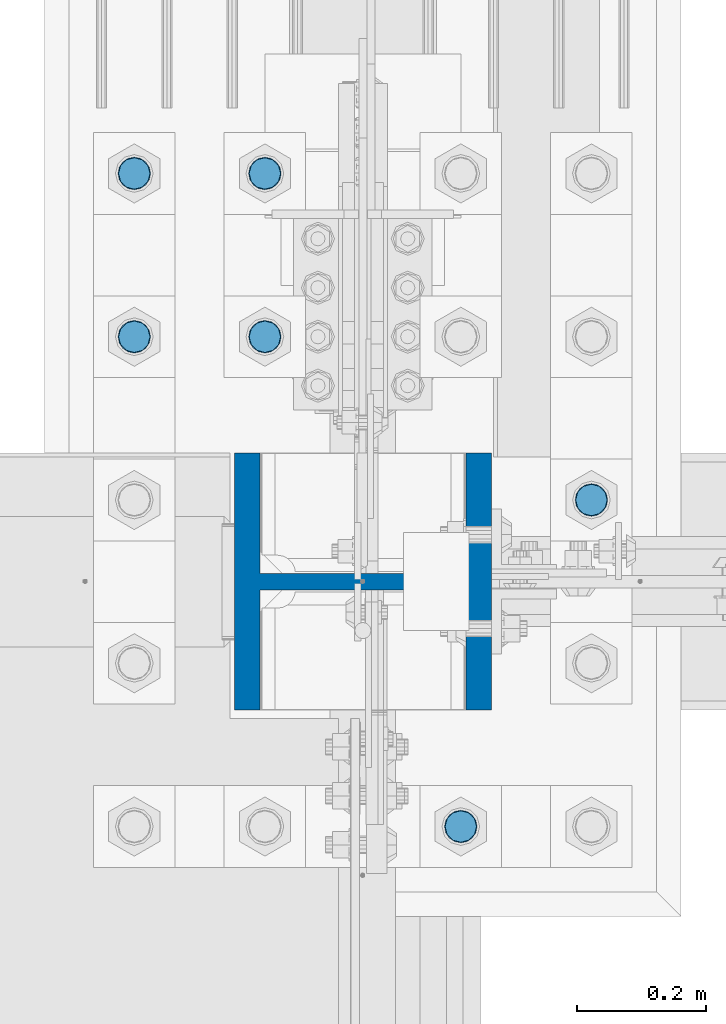
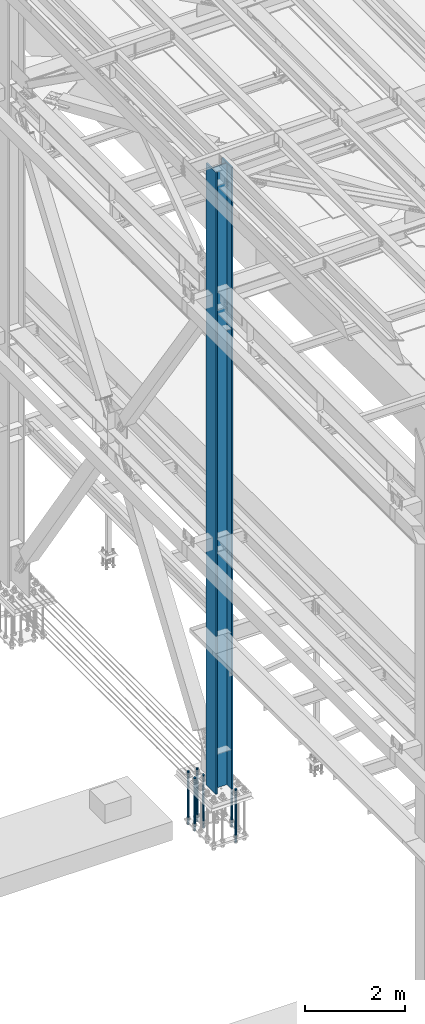
# One storey, part 1327 of 3843: 7 columns, 2 elements without a shape of their own.
"""IFC2X3 building model written with IfcOpenShell, lengths in millimetres."""

from ifc_helpers import new_model, si_unit, frame, origin_with_axes, place, context, subcontext, project, spatial, faceted_brep, material, type_object, element, aggregate, save


model = new_model("IFC2X3")

# Units and contexts
model_context = context("Model", 3, precision=1e-05, world=origin_with_axes())
body_context = subcontext(model_context, "Body", "Model", "MODEL_VIEW")
ifc_project = project(units=[si_unit("LENGTHUNIT", "METRE", prefix="MILLI"), si_unit("AREAUNIT", "SQUARE_METRE"), si_unit("VOLUMEUNIT", "CUBIC_METRE"), si_unit("MASSUNIT", "GRAM", prefix="KILO"), si_unit("TIMEUNIT", "SECOND"), si_unit("PLANEANGLEUNIT", "RADIAN"), si_unit("SOLIDANGLEUNIT", "STERADIAN"), si_unit("THERMODYNAMICTEMPERATUREUNIT", "DEGREE_CELSIUS"), si_unit("LUMINOUSINTENSITYUNIT", "LUMEN")], contexts=[model_context])

# Site, building, storey
site_placement = place(None, origin_with_axes())
site = spatial("IfcSite", under=ifc_project, at=site_placement, CompositionType="ELEMENT")
building_placement = place(site_placement, origin_with_axes())
building = spatial("IfcBuilding", under=site, at=building_placement, Name="Undefined", CompositionType="ELEMENT")
storey_placement = place(building_placement, origin_with_axes())
storey = spatial("IfcBuildingStorey", under=building, at=storey_placement, Name="Undefined", CompositionType="ELEMENT", Elevation=0.0)

# Assembly, columns
assembly_1_placement = place(storey_placement, origin_with_axes())
assembly_1 = element("IfcElementAssembly", 1, at=assembly_1_placement, inside=storey, Name="TEMPLATE", AssemblyPlace="NOTDEFINED", PredefinedType="RIGID_FRAME")
ifc_material_1 = material(Name="Undefined/F1554-GR.55")
column_type_1 = type_object("IfcColumnType", PredefinedType="NOTDEFINED")
column_1_placement = place(assembly_1_placement, frame((36931.6, 50685.7, 30022.8), z_axis=(1.0, 0.0, 0.0), x_axis=(0.0, 0.0, -1.0)))
column_1 = element("IfcColumn", 2, at=column_1_placement, type_object=column_type_1, material=ifc_material_1, Name="ANCHOR_ROD", context=body_context, shape_type="Brep", body=[
    faceted_brep([(-266.700000000001, -21.2176223927236, 12.25), (-266.700000000001, -12.25, 21.2176223927163), (-266.700000000001, 0.0, 24.5), (-266.700000000001, 12.25, 21.2176223927163), (-266.700000000001, 21.2176223927236, 12.25), (-266.700000000001, 24.5, 0.0), (-266.700000000001, 21.2176223927236, -12.25), (-266.700000000001, 12.25, -21.2176223927163), (-266.700000000001, 0.0, -24.5), (-266.700000000001, -12.25, -21.2176223927163), (-266.700000000001, -21.2176223927236, -12.25), (-266.700000000001, -24.5, 0.0), (0.0, 24.5000000000146, 0.0), (0.0, 21.2176223927381, -12.25), (0.0, 12.2500000000146, -21.2176223927163), (0.0, 1.45519152283669e-11, -24.5), (0.0, -12.2499999999854, -21.2176223927163), (0.0, -21.217622392709, -12.25), (0.0, -24.4999999999854, 0.0), (0.0, -21.217622392709, 12.25), (0.0, -12.2499999999854, 21.2176223927163), (0.0, 1.45519152283669e-11, 24.5), (0.0, 12.2500000000146, 21.2176223927163), (0.0, 21.2176223927381, 12.25), (0.0, -23.4665401257807, 9.72015918207035), (0.0, -17.9605122421344, 17.9605122421417), (0.0, -9.72015918207762, 23.466540125788), (0.0, 0.0, 25.4000000000015), (0.0, 9.72015918207762, 23.466540125788), (0.0, 17.9605122421344, 17.9605122421417), (0.0, 23.4665401257807, 9.72015918207035), (0.0, 25.3999996185303, 0.0), (0.0, 23.4665401257807, -9.72015918207035), (0.0, 17.9605122421344, -17.9605122421417), (0.0, 9.72015918207762, -23.466540125788), (0.0, 0.0, -25.4000000000015), (0.0, -9.72015918207762, -23.466540125788), (0.0, -17.9605122421344, -17.9605122421417), (0.0, -23.4665401257807, -9.72015918207035), (0.0, -25.3999996185303, 0.0), (812.799999999999, -25.4000000000015, 0.0), (812.799999999999, -23.466540125788, 9.72015918207398), (812.799999999999, -17.9605122421417, 17.9605122421381), (812.799999999999, -9.72015918207035, 23.466540125788), (812.799999999999, 0.0, 25.4000000000015), (812.799999999999, 9.72015918207035, 23.466540125788), (812.799999999999, 17.9605122421417, 17.9605122421381), (812.799999999999, 23.466540125788, 9.72015918207398), (812.799999999999, 25.4000000000015, 0.0), (812.799999999999, 23.466540125788, -9.72015918207398), (812.799999999999, 17.9605122421417, -17.9605122421381), (812.799999999999, 9.72015918207035, -23.466540125788), (812.799999999999, 0.0, -25.4000000000015), (812.799999999999, -9.72015918207035, -23.466540125788), (812.799999999999, -17.9605122421417, -17.9605122421381), (812.799999999999, -23.466540125788, -9.72015918207398), (812.799999999999, -12.25, 21.2176223927199), (812.799999999999, 0.0, 24.5), (812.799999999999, 12.25, 21.2176223927199), (812.799999999999, 21.2176223927163, 12.25), (812.799999999999, 24.5, 0.0), (812.799999999999, 21.2176223927163, -12.25), (812.799999999999, 12.25, -21.2176223927199), (812.799999999999, 0.0, -24.5), (812.799999999999, -12.25, -21.2176223927199), (812.799999999999, -21.2176223927163, -12.25), (812.799999999999, -24.5, 0.0), (812.799999999999, -21.2176223927163, 12.25), (1041.4, -12.25, -21.2176223927199), (1041.4, 0.0, -24.5), (1041.4, 12.25, -21.2176223927199), (1041.4, 21.2176223927163, -12.25), (1041.4, 24.5, 0.0), (1041.4, 21.2176223927163, 12.25), (1041.4, 12.25, 21.2176223927199), (1041.4, 0.0, 24.5), (1041.4, -12.25, 21.2176223927199), (1041.4, -21.2176223927163, 12.25), (1041.4, -24.5, 0.0), (1041.4, -21.2176223927163, -12.25)], [[[0, 1, 2, 3, 4, 5, 6, 7, 8, 9, 10, 11]], [[6, 5, 12, 13]], [[7, 6, 13, 14]], [[8, 7, 14, 15]], [[9, 8, 15, 16]], [[10, 9, 16, 17]], [[11, 10, 17, 18]], [[0, 11, 18, 19]], [[1, 0, 19, 20]], [[2, 1, 20, 21]], [[3, 2, 21, 22]], [[4, 3, 22, 23]], [[5, 4, 23, 12]], [[24, 25, 26, 27, 28, 29, 30, 31, 32, 33, 34, 35, 36, 37, 38, 39], [22, 21, 20, 19, 18, 17, 16, 15, 14, 13, 12, 23]], [[24, 39, 40, 41]], [[25, 24, 41, 42]], [[26, 25, 42, 43]], [[27, 26, 43, 44]], [[28, 27, 44, 45]], [[29, 28, 45, 46]], [[30, 29, 46, 47]], [[31, 30, 47, 48]], [[32, 31, 48, 49]], [[33, 32, 49, 50]], [[34, 33, 50, 51]], [[35, 34, 51, 52]], [[36, 35, 52, 53]], [[37, 36, 53, 54]], [[38, 37, 54, 55]], [[39, 38, 55, 40]], [[54, 53, 52, 51, 50, 49, 48, 47, 46, 45, 44, 43, 42, 41, 40, 55], [56, 57, 58, 59, 60, 61, 62, 63, 64, 65, 66, 67]], [[68, 69, 70, 71, 72, 73, 74, 75, 76, 77, 78, 79]], [[76, 75, 57, 56]], [[77, 76, 56, 67]], [[78, 77, 67, 66]], [[79, 78, 66, 65]], [[68, 79, 65, 64]], [[69, 68, 64, 63]], [[70, 69, 63, 62]], [[71, 70, 62, 61]], [[72, 71, 61, 60]], [[73, 72, 60, 59]], [[74, 73, 59, 58]], [[75, 74, 58, 57]]]),
])
column_2_placement = place(assembly_1_placement, frame((36728.4, 50177.7, 30022.8), z_axis=(1.0, 0.0, 0.0), x_axis=(0.0, 0.0, -1.0)))
column_2 = element("IfcColumn", 3, at=column_2_placement, type_object=column_type_1, material=ifc_material_1, Name="ANCHOR_ROD", context=body_context, shape_type="Brep", body=[
    faceted_brep([(-266.700000000001, -21.2176223927236, 12.25), (-266.700000000001, -12.25, 21.2176223927163), (-266.700000000001, 0.0, 24.5), (-266.700000000001, 12.25, 21.2176223927163), (-266.700000000001, 21.2176223927236, 12.25), (-266.700000000001, 24.5, 0.0), (-266.700000000001, 21.2176223927236, -12.25), (-266.700000000001, 12.25, -21.2176223927163), (-266.700000000001, 0.0, -24.5), (-266.700000000001, -12.25, -21.2176223927163), (-266.700000000001, -21.2176223927236, -12.25), (-266.700000000001, -24.5, 0.0), (0.0, 24.5000000000146, 0.0), (0.0, 21.2176223927381, -12.25), (0.0, 12.2500000000146, -21.2176223927163), (0.0, 1.45519152283669e-11, -24.5), (0.0, -12.2499999999854, -21.2176223927163), (0.0, -21.217622392709, -12.25), (0.0, -24.4999999999854, 0.0), (0.0, -21.217622392709, 12.25), (0.0, -12.2499999999854, 21.2176223927163), (0.0, 1.45519152283669e-11, 24.5), (0.0, 12.2500000000146, 21.2176223927163), (0.0, 21.2176223927381, 12.25), (0.0, -23.4665401257807, 9.72015918207035), (0.0, -17.9605122421344, 17.9605122421417), (0.0, -9.72015918207762, 23.466540125788), (0.0, 0.0, 25.4000000000015), (0.0, 9.72015918207762, 23.466540125788), (0.0, 17.9605122421344, 17.9605122421417), (0.0, 23.4665401257807, 9.72015918207035), (0.0, 25.3999996185303, 0.0), (0.0, 23.4665401257807, -9.72015918207035), (0.0, 17.9605122421344, -17.9605122421417), (0.0, 9.72015918207762, -23.466540125788), (0.0, 0.0, -25.4000000000015), (0.0, -9.72015918207762, -23.466540125788), (0.0, -17.9605122421344, -17.9605122421417), (0.0, -23.4665401257807, -9.72015918207035), (0.0, -25.3999996185303, 0.0), (812.799999999999, -25.4000000000015, 0.0), (812.799999999999, -23.466540125788, 9.72015918207398), (812.799999999999, -17.9605122421417, 17.9605122421381), (812.799999999999, -9.72015918207035, 23.466540125788), (812.799999999999, 0.0, 25.4000000000015), (812.799999999999, 9.72015918207035, 23.466540125788), (812.799999999999, 17.9605122421417, 17.9605122421381), (812.799999999999, 23.466540125788, 9.72015918207398), (812.799999999999, 25.4000000000015, 0.0), (812.799999999999, 23.466540125788, -9.72015918207398), (812.799999999999, 17.9605122421417, -17.9605122421381), (812.799999999999, 9.72015918207035, -23.466540125788), (812.799999999999, 0.0, -25.4000000000015), (812.799999999999, -9.72015918207035, -23.466540125788), (812.799999999999, -17.9605122421417, -17.9605122421381), (812.799999999999, -23.466540125788, -9.72015918207398), (812.799999999999, -12.25, 21.2176223927199), (812.799999999999, 0.0, 24.5), (812.799999999999, 12.25, 21.2176223927199), (812.799999999999, 21.2176223927163, 12.25), (812.799999999999, 24.5, 0.0), (812.799999999999, 21.2176223927163, -12.25), (812.799999999999, 12.25, -21.2176223927199), (812.799999999999, 0.0, -24.5), (812.799999999999, -12.25, -21.2176223927199), (812.799999999999, -21.2176223927163, -12.25), (812.799999999999, -24.5, 0.0), (812.799999999999, -21.2176223927163, 12.25), (1041.4, -12.25, -21.2176223927199), (1041.4, 0.0, -24.5), (1041.4, 12.25, -21.2176223927199), (1041.4, 21.2176223927163, -12.25), (1041.4, 24.5, 0.0), (1041.4, 21.2176223927163, 12.25), (1041.4, 12.25, 21.2176223927199), (1041.4, 0.0, 24.5), (1041.4, -12.25, 21.2176223927199), (1041.4, -21.2176223927163, 12.25), (1041.4, -24.5, 0.0), (1041.4, -21.2176223927163, -12.25)], [[[0, 1, 2, 3, 4, 5, 6, 7, 8, 9, 10, 11]], [[6, 5, 12, 13]], [[7, 6, 13, 14]], [[8, 7, 14, 15]], [[9, 8, 15, 16]], [[10, 9, 16, 17]], [[11, 10, 17, 18]], [[0, 11, 18, 19]], [[1, 0, 19, 20]], [[2, 1, 20, 21]], [[3, 2, 21, 22]], [[4, 3, 22, 23]], [[5, 4, 23, 12]], [[24, 25, 26, 27, 28, 29, 30, 31, 32, 33, 34, 35, 36, 37, 38, 39], [22, 21, 20, 19, 18, 17, 16, 15, 14, 13, 12, 23]], [[24, 39, 40, 41]], [[25, 24, 41, 42]], [[26, 25, 42, 43]], [[27, 26, 43, 44]], [[28, 27, 44, 45]], [[29, 28, 45, 46]], [[30, 29, 46, 47]], [[31, 30, 47, 48]], [[32, 31, 48, 49]], [[33, 32, 49, 50]], [[34, 33, 50, 51]], [[35, 34, 51, 52]], [[36, 35, 52, 53]], [[37, 36, 53, 54]], [[38, 37, 54, 55]], [[39, 38, 55, 40]], [[54, 53, 52, 51, 50, 49, 48, 47, 46, 45, 44, 43, 42, 41, 40, 55], [56, 57, 58, 59, 60, 61, 62, 63, 64, 65, 66, 67]], [[68, 69, 70, 71, 72, 73, 74, 75, 76, 77, 78, 79]], [[76, 75, 57, 56]], [[77, 76, 56, 67]], [[78, 77, 67, 66]], [[79, 78, 66, 65]], [[68, 79, 65, 64]], [[69, 68, 64, 63]], [[70, 69, 63, 62]], [[71, 70, 62, 61]], [[72, 71, 61, 60]], [[73, 72, 60, 59]], [[74, 73, 59, 58]], [[75, 74, 58, 57]]]),
])
column_3_placement = place(assembly_1_placement, frame((36423.6, 50939.7, 30022.8), z_axis=(-1.0, 0.0, 0.0), x_axis=(0.0, 0.0, -1.0)))
column_3 = element("IfcColumn", 4, at=column_3_placement, type_object=column_type_1, material=ifc_material_1, Name="ANCHOR_ROD", context=body_context, shape_type="Brep", body=[
    faceted_brep([(-266.700000000001, -21.2176223927236, 12.25), (-266.700000000001, -12.25, 21.2176223927163), (-266.700000000001, 0.0, 24.5), (-266.700000000001, 12.25, 21.2176223927163), (-266.700000000001, 21.2176223927236, 12.25), (-266.700000000001, 24.5, 0.0), (-266.700000000001, 21.2176223927236, -12.25), (-266.700000000001, 12.25, -21.2176223927163), (-266.700000000001, 0.0, -24.5), (-266.700000000001, -12.25, -21.2176223927163), (-266.700000000001, -21.2176223927236, -12.25), (-266.700000000001, -24.5, 0.0), (0.0, 24.5000000000146, 0.0), (0.0, 21.2176223927381, -12.25), (0.0, 12.2500000000146, -21.2176223927163), (0.0, 1.45519152283669e-11, -24.5), (0.0, -12.2499999999854, -21.2176223927163), (0.0, -21.217622392709, -12.25), (0.0, -24.4999999999854, 0.0), (0.0, -21.217622392709, 12.25), (0.0, -12.2499999999854, 21.2176223927163), (0.0, 1.45519152283669e-11, 24.5), (0.0, 12.2500000000146, 21.2176223927163), (0.0, 21.2176223927381, 12.25), (0.0, -23.4665401257807, 9.72015918207035), (0.0, -17.9605122421344, 17.9605122421417), (0.0, -9.72015918207762, 23.466540125788), (0.0, 0.0, 25.4000000000015), (0.0, 9.72015918207762, 23.466540125788), (0.0, 17.9605122421344, 17.9605122421417), (0.0, 23.4665401257807, 9.72015918207035), (0.0, 25.3999996185303, 0.0), (0.0, 23.4665401257807, -9.72015918207035), (0.0, 17.9605122421344, -17.9605122421417), (0.0, 9.72015918207762, -23.466540125788), (0.0, 0.0, -25.4000000000015), (0.0, -9.72015918207762, -23.466540125788), (0.0, -17.9605122421344, -17.9605122421417), (0.0, -23.4665401257807, -9.72015918207035), (0.0, -25.3999996185303, 0.0), (812.799999999999, -25.4000000000015, 0.0), (812.799999999999, -23.466540125788, 9.72015918207398), (812.799999999999, -17.9605122421417, 17.9605122421381), (812.799999999999, -9.72015918207035, 23.466540125788), (812.799999999999, 0.0, 25.4000000000015), (812.799999999999, 9.72015918207035, 23.466540125788), (812.799999999999, 17.9605122421417, 17.9605122421381), (812.799999999999, 23.466540125788, 9.72015918207398), (812.799999999999, 25.4000000000015, 0.0), (812.799999999999, 23.466540125788, -9.72015918207398), (812.799999999999, 17.9605122421417, -17.9605122421381), (812.799999999999, 9.72015918207035, -23.466540125788), (812.799999999999, 0.0, -25.4000000000015), (812.799999999999, -9.72015918207035, -23.466540125788), (812.799999999999, -17.9605122421417, -17.9605122421381), (812.799999999999, -23.466540125788, -9.72015918207398), (812.799999999999, -12.25, 21.2176223927199), (812.799999999999, 0.0, 24.5), (812.799999999999, 12.25, 21.2176223927199), (812.799999999999, 21.2176223927163, 12.25), (812.799999999999, 24.5, 0.0), (812.799999999999, 21.2176223927163, -12.25), (812.799999999999, 12.25, -21.2176223927199), (812.799999999999, 0.0, -24.5), (812.799999999999, -12.25, -21.2176223927199), (812.799999999999, -21.2176223927163, -12.25), (812.799999999999, -24.5, 0.0), (812.799999999999, -21.2176223927163, 12.25), (1041.4, -12.25, -21.2176223927199), (1041.4, 0.0, -24.5), (1041.4, 12.25, -21.2176223927199), (1041.4, 21.2176223927163, -12.25), (1041.4, 24.5, 0.0), (1041.4, 21.2176223927163, 12.25), (1041.4, 12.25, 21.2176223927199), (1041.4, 0.0, 24.5), (1041.4, -12.25, 21.2176223927199), (1041.4, -21.2176223927163, 12.25), (1041.4, -24.5, 0.0), (1041.4, -21.2176223927163, -12.25)], [[[0, 1, 2, 3, 4, 5, 6, 7, 8, 9, 10, 11]], [[6, 5, 12, 13]], [[7, 6, 13, 14]], [[8, 7, 14, 15]], [[9, 8, 15, 16]], [[10, 9, 16, 17]], [[11, 10, 17, 18]], [[0, 11, 18, 19]], [[1, 0, 19, 20]], [[2, 1, 20, 21]], [[3, 2, 21, 22]], [[4, 3, 22, 23]], [[5, 4, 23, 12]], [[24, 25, 26, 27, 28, 29, 30, 31, 32, 33, 34, 35, 36, 37, 38, 39], [22, 21, 20, 19, 18, 17, 16, 15, 14, 13, 12, 23]], [[24, 39, 40, 41]], [[25, 24, 41, 42]], [[26, 25, 42, 43]], [[27, 26, 43, 44]], [[28, 27, 44, 45]], [[29, 28, 45, 46]], [[30, 29, 46, 47]], [[31, 30, 47, 48]], [[32, 31, 48, 49]], [[33, 32, 49, 50]], [[34, 33, 50, 51]], [[35, 34, 51, 52]], [[36, 35, 52, 53]], [[37, 36, 53, 54]], [[38, 37, 54, 55]], [[39, 38, 55, 40]], [[54, 53, 52, 51, 50, 49, 48, 47, 46, 45, 44, 43, 42, 41, 40, 55], [56, 57, 58, 59, 60, 61, 62, 63, 64, 65, 66, 67]], [[68, 69, 70, 71, 72, 73, 74, 75, 76, 77, 78, 79]], [[76, 75, 57, 56]], [[77, 76, 56, 67]], [[78, 77, 67, 66]], [[79, 78, 66, 65]], [[68, 79, 65, 64]], [[69, 68, 64, 63]], [[70, 69, 63, 62]], [[71, 70, 62, 61]], [[72, 71, 61, 60]], [[73, 72, 60, 59]], [[74, 73, 59, 58]], [[75, 74, 58, 57]]]),
])
column_4_placement = place(assembly_1_placement, frame((36423.6, 51193.7, 30022.8), z_axis=(-1.0, 0.0, 0.0), x_axis=(0.0, 0.0, -1.0)))
column_4 = element("IfcColumn", 5, at=column_4_placement, type_object=column_type_1, material=ifc_material_1, Name="ANCHOR_ROD", context=body_context, shape_type="Brep", body=[
    faceted_brep([(-266.700000000001, -21.2176223927236, 12.25), (-266.700000000001, -12.25, 21.2176223927163), (-266.700000000001, 0.0, 24.5), (-266.700000000001, 12.25, 21.2176223927163), (-266.700000000001, 21.2176223927236, 12.25), (-266.700000000001, 24.5, 0.0), (-266.700000000001, 21.2176223927236, -12.25), (-266.700000000001, 12.25, -21.2176223927163), (-266.700000000001, 0.0, -24.5), (-266.700000000001, -12.25, -21.2176223927163), (-266.700000000001, -21.2176223927236, -12.25), (-266.700000000001, -24.5, 0.0), (0.0, 24.5000000000146, 0.0), (0.0, 21.2176223927381, -12.25), (0.0, 12.2500000000146, -21.2176223927163), (0.0, 1.45519152283669e-11, -24.5), (0.0, -12.2499999999854, -21.2176223927163), (0.0, -21.217622392709, -12.25), (0.0, -24.4999999999854, 0.0), (0.0, -21.217622392709, 12.25), (0.0, -12.2499999999854, 21.2176223927163), (0.0, 1.45519152283669e-11, 24.5), (0.0, 12.2500000000146, 21.2176223927163), (0.0, 21.2176223927381, 12.25), (0.0, -23.4665401257807, 9.72015918207035), (0.0, -17.9605122421344, 17.9605122421417), (0.0, -9.72015918207762, 23.466540125788), (0.0, 0.0, 25.4000000000015), (0.0, 9.72015918207762, 23.466540125788), (0.0, 17.9605122421344, 17.9605122421417), (0.0, 23.4665401257807, 9.72015918207035), (0.0, 25.3999996185303, 0.0), (0.0, 23.4665401257807, -9.72015918207035), (0.0, 17.9605122421344, -17.9605122421417), (0.0, 9.72015918207762, -23.466540125788), (0.0, 0.0, -25.4000000000015), (0.0, -9.72015918207762, -23.466540125788), (0.0, -17.9605122421344, -17.9605122421417), (0.0, -23.4665401257807, -9.72015918207035), (0.0, -25.3999996185303, 0.0), (812.799999999999, -25.4000000000015, 0.0), (812.799999999999, -23.466540125788, 9.72015918207398), (812.799999999999, -17.9605122421417, 17.9605122421381), (812.799999999999, -9.72015918207035, 23.466540125788), (812.799999999999, 0.0, 25.4000000000015), (812.799999999999, 9.72015918207035, 23.466540125788), (812.799999999999, 17.9605122421417, 17.9605122421381), (812.799999999999, 23.466540125788, 9.72015918207398), (812.799999999999, 25.4000000000015, 0.0), (812.799999999999, 23.466540125788, -9.72015918207398), (812.799999999999, 17.9605122421417, -17.9605122421381), (812.799999999999, 9.72015918207035, -23.466540125788), (812.799999999999, 0.0, -25.4000000000015), (812.799999999999, -9.72015918207035, -23.466540125788), (812.799999999999, -17.9605122421417, -17.9605122421381), (812.799999999999, -23.466540125788, -9.72015918207398), (812.799999999999, -12.25, 21.2176223927199), (812.799999999999, 0.0, 24.5), (812.799999999999, 12.25, 21.2176223927199), (812.799999999999, 21.2176223927163, 12.25), (812.799999999999, 24.5, 0.0), (812.799999999999, 21.2176223927163, -12.25), (812.799999999999, 12.25, -21.2176223927199), (812.799999999999, 0.0, -24.5), (812.799999999999, -12.25, -21.2176223927199), (812.799999999999, -21.2176223927163, -12.25), (812.799999999999, -24.5, 0.0), (812.799999999999, -21.2176223927163, 12.25), (1041.4, -12.25, -21.2176223927199), (1041.4, 0.0, -24.5), (1041.4, 12.25, -21.2176223927199), (1041.4, 21.2176223927163, -12.25), (1041.4, 24.5, 0.0), (1041.4, 21.2176223927163, 12.25), (1041.4, 12.25, 21.2176223927199), (1041.4, 0.0, 24.5), (1041.4, -12.25, 21.2176223927199), (1041.4, -21.2176223927163, 12.25), (1041.4, -24.5, 0.0), (1041.4, -21.2176223927163, -12.25)], [[[0, 1, 2, 3, 4, 5, 6, 7, 8, 9, 10, 11]], [[6, 5, 12, 13]], [[7, 6, 13, 14]], [[8, 7, 14, 15]], [[9, 8, 15, 16]], [[10, 9, 16, 17]], [[11, 10, 17, 18]], [[0, 11, 18, 19]], [[1, 0, 19, 20]], [[2, 1, 20, 21]], [[3, 2, 21, 22]], [[4, 3, 22, 23]], [[5, 4, 23, 12]], [[24, 25, 26, 27, 28, 29, 30, 31, 32, 33, 34, 35, 36, 37, 38, 39], [22, 21, 20, 19, 18, 17, 16, 15, 14, 13, 12, 23]], [[24, 39, 40, 41]], [[25, 24, 41, 42]], [[26, 25, 42, 43]], [[27, 26, 43, 44]], [[28, 27, 44, 45]], [[29, 28, 45, 46]], [[30, 29, 46, 47]], [[31, 30, 47, 48]], [[32, 31, 48, 49]], [[33, 32, 49, 50]], [[34, 33, 50, 51]], [[35, 34, 51, 52]], [[36, 35, 52, 53]], [[37, 36, 53, 54]], [[38, 37, 54, 55]], [[39, 38, 55, 40]], [[54, 53, 52, 51, 50, 49, 48, 47, 46, 45, 44, 43, 42, 41, 40, 55], [56, 57, 58, 59, 60, 61, 62, 63, 64, 65, 66, 67]], [[68, 69, 70, 71, 72, 73, 74, 75, 76, 77, 78, 79]], [[76, 75, 57, 56]], [[77, 76, 56, 67]], [[78, 77, 67, 66]], [[79, 78, 66, 65]], [[68, 79, 65, 64]], [[69, 68, 64, 63]], [[70, 69, 63, 62]], [[71, 70, 62, 61]], [[72, 71, 61, 60]], [[73, 72, 60, 59]], [[74, 73, 59, 58]], [[75, 74, 58, 57]]]),
])
column_5_placement = place(assembly_1_placement, frame((36220.4, 50939.7, 30022.8), z_axis=(-1.0, 0.0, 0.0), x_axis=(0.0, 0.0, -1.0)))
column_5 = element("IfcColumn", 6, at=column_5_placement, type_object=column_type_1, material=ifc_material_1, Name="ANCHOR_ROD", context=body_context, shape_type="Brep", body=[
    faceted_brep([(-266.700000000001, -21.2176223927236, 12.25), (-266.700000000001, -12.25, 21.2176223927163), (-266.700000000001, 0.0, 24.5), (-266.700000000001, 12.25, 21.2176223927163), (-266.700000000001, 21.2176223927236, 12.25), (-266.700000000001, 24.5, 0.0), (-266.700000000001, 21.2176223927236, -12.25), (-266.700000000001, 12.25, -21.2176223927163), (-266.700000000001, 0.0, -24.5), (-266.700000000001, -12.25, -21.2176223927163), (-266.700000000001, -21.2176223927236, -12.25), (-266.700000000001, -24.5, 0.0), (0.0, 24.5000000000146, 0.0), (0.0, 21.2176223927381, -12.25), (0.0, 12.2500000000146, -21.2176223927163), (0.0, 1.45519152283669e-11, -24.5), (0.0, -12.2499999999854, -21.2176223927163), (0.0, -21.217622392709, -12.25), (0.0, -24.4999999999854, 0.0), (0.0, -21.217622392709, 12.25), (0.0, -12.2499999999854, 21.2176223927163), (0.0, 1.45519152283669e-11, 24.5), (0.0, 12.2500000000146, 21.2176223927163), (0.0, 21.2176223927381, 12.25), (0.0, -23.4665401257807, 9.72015918207035), (0.0, -17.9605122421344, 17.9605122421417), (0.0, -9.72015918207762, 23.466540125788), (0.0, 0.0, 25.4000000000015), (0.0, 9.72015918207762, 23.466540125788), (0.0, 17.9605122421344, 17.9605122421417), (0.0, 23.4665401257807, 9.72015918207035), (0.0, 25.3999996185303, 0.0), (0.0, 23.4665401257807, -9.72015918207035), (0.0, 17.9605122421344, -17.9605122421417), (0.0, 9.72015918207762, -23.466540125788), (0.0, 0.0, -25.4000000000015), (0.0, -9.72015918207762, -23.466540125788), (0.0, -17.9605122421344, -17.9605122421417), (0.0, -23.4665401257807, -9.72015918207035), (0.0, -25.3999996185303, 0.0), (812.799999999999, -25.4000000000015, 0.0), (812.799999999999, -23.466540125788, 9.72015918207398), (812.799999999999, -17.9605122421417, 17.9605122421381), (812.799999999999, -9.72015918207035, 23.466540125788), (812.799999999999, 0.0, 25.4000000000015), (812.799999999999, 9.72015918207035, 23.466540125788), (812.799999999999, 17.9605122421417, 17.9605122421381), (812.799999999999, 23.466540125788, 9.72015918207398), (812.799999999999, 25.4000000000015, 0.0), (812.799999999999, 23.466540125788, -9.72015918207398), (812.799999999999, 17.9605122421417, -17.9605122421381), (812.799999999999, 9.72015918207035, -23.466540125788), (812.799999999999, 0.0, -25.4000000000015), (812.799999999999, -9.72015918207035, -23.466540125788), (812.799999999999, -17.9605122421417, -17.9605122421381), (812.799999999999, -23.466540125788, -9.72015918207398), (812.799999999999, -12.25, 21.2176223927199), (812.799999999999, 0.0, 24.5), (812.799999999999, 12.25, 21.2176223927199), (812.799999999999, 21.2176223927163, 12.25), (812.799999999999, 24.5, 0.0), (812.799999999999, 21.2176223927163, -12.25), (812.799999999999, 12.25, -21.2176223927199), (812.799999999999, 0.0, -24.5), (812.799999999999, -12.25, -21.2176223927199), (812.799999999999, -21.2176223927163, -12.25), (812.799999999999, -24.5, 0.0), (812.799999999999, -21.2176223927163, 12.25), (1041.4, -12.25, -21.2176223927199), (1041.4, 0.0, -24.5), (1041.4, 12.25, -21.2176223927199), (1041.4, 21.2176223927163, -12.25), (1041.4, 24.5, 0.0), (1041.4, 21.2176223927163, 12.25), (1041.4, 12.25, 21.2176223927199), (1041.4, 0.0, 24.5), (1041.4, -12.25, 21.2176223927199), (1041.4, -21.2176223927163, 12.25), (1041.4, -24.5, 0.0), (1041.4, -21.2176223927163, -12.25)], [[[0, 1, 2, 3, 4, 5, 6, 7, 8, 9, 10, 11]], [[6, 5, 12, 13]], [[7, 6, 13, 14]], [[8, 7, 14, 15]], [[9, 8, 15, 16]], [[10, 9, 16, 17]], [[11, 10, 17, 18]], [[0, 11, 18, 19]], [[1, 0, 19, 20]], [[2, 1, 20, 21]], [[3, 2, 21, 22]], [[4, 3, 22, 23]], [[5, 4, 23, 12]], [[24, 25, 26, 27, 28, 29, 30, 31, 32, 33, 34, 35, 36, 37, 38, 39], [22, 21, 20, 19, 18, 17, 16, 15, 14, 13, 12, 23]], [[24, 39, 40, 41]], [[25, 24, 41, 42]], [[26, 25, 42, 43]], [[27, 26, 43, 44]], [[28, 27, 44, 45]], [[29, 28, 45, 46]], [[30, 29, 46, 47]], [[31, 30, 47, 48]], [[32, 31, 48, 49]], [[33, 32, 49, 50]], [[34, 33, 50, 51]], [[35, 34, 51, 52]], [[36, 35, 52, 53]], [[37, 36, 53, 54]], [[38, 37, 54, 55]], [[39, 38, 55, 40]], [[54, 53, 52, 51, 50, 49, 48, 47, 46, 45, 44, 43, 42, 41, 40, 55], [56, 57, 58, 59, 60, 61, 62, 63, 64, 65, 66, 67]], [[68, 69, 70, 71, 72, 73, 74, 75, 76, 77, 78, 79]], [[76, 75, 57, 56]], [[77, 76, 56, 67]], [[78, 77, 67, 66]], [[79, 78, 66, 65]], [[68, 79, 65, 64]], [[69, 68, 64, 63]], [[70, 69, 63, 62]], [[71, 70, 62, 61]], [[72, 71, 61, 60]], [[73, 72, 60, 59]], [[74, 73, 59, 58]], [[75, 74, 58, 57]]]),
])
column_6_placement = place(assembly_1_placement, frame((36220.4, 51193.7, 30022.8), z_axis=(-1.0, 0.0, 0.0), x_axis=(0.0, 0.0, -1.0)))
column_6 = element("IfcColumn", 7, at=column_6_placement, type_object=column_type_1, material=ifc_material_1, Name="ANCHOR_ROD", context=body_context, shape_type="Brep", body=[
    faceted_brep([(-266.700000000001, -21.2176223927236, 12.25), (-266.700000000001, -12.25, 21.2176223927163), (-266.700000000001, 0.0, 24.5), (-266.700000000001, 12.25, 21.2176223927163), (-266.700000000001, 21.2176223927236, 12.25), (-266.700000000001, 24.5, 0.0), (-266.700000000001, 21.2176223927236, -12.25), (-266.700000000001, 12.25, -21.2176223927163), (-266.700000000001, 0.0, -24.5), (-266.700000000001, -12.25, -21.2176223927163), (-266.700000000001, -21.2176223927236, -12.25), (-266.700000000001, -24.5, 0.0), (0.0, 24.5000000000146, 0.0), (0.0, 21.2176223927381, -12.25), (0.0, 12.2500000000146, -21.2176223927163), (0.0, 1.45519152283669e-11, -24.5), (0.0, -12.2499999999854, -21.2176223927163), (0.0, -21.217622392709, -12.25), (0.0, -24.4999999999854, 0.0), (0.0, -21.217622392709, 12.25), (0.0, -12.2499999999854, 21.2176223927163), (0.0, 1.45519152283669e-11, 24.5), (0.0, 12.2500000000146, 21.2176223927163), (0.0, 21.2176223927381, 12.25), (0.0, -23.4665401257807, 9.72015918207035), (0.0, -17.9605122421344, 17.9605122421417), (0.0, -9.72015918207762, 23.466540125788), (0.0, 0.0, 25.4000000000015), (0.0, 9.72015918207762, 23.466540125788), (0.0, 17.9605122421344, 17.9605122421417), (0.0, 23.4665401257807, 9.72015918207035), (0.0, 25.3999996185303, 0.0), (0.0, 23.4665401257807, -9.72015918207035), (0.0, 17.9605122421344, -17.9605122421417), (0.0, 9.72015918207762, -23.466540125788), (0.0, 0.0, -25.4000000000015), (0.0, -9.72015918207762, -23.466540125788), (0.0, -17.9605122421344, -17.9605122421417), (0.0, -23.4665401257807, -9.72015918207035), (0.0, -25.3999996185303, 0.0), (812.799999999999, -25.4000000000015, 0.0), (812.799999999999, -23.466540125788, 9.72015918207398), (812.799999999999, -17.9605122421417, 17.9605122421381), (812.799999999999, -9.72015918207035, 23.466540125788), (812.799999999999, 0.0, 25.4000000000015), (812.799999999999, 9.72015918207035, 23.466540125788), (812.799999999999, 17.9605122421417, 17.9605122421381), (812.799999999999, 23.466540125788, 9.72015918207398), (812.799999999999, 25.4000000000015, 0.0), (812.799999999999, 23.466540125788, -9.72015918207398), (812.799999999999, 17.9605122421417, -17.9605122421381), (812.799999999999, 9.72015918207035, -23.466540125788), (812.799999999999, 0.0, -25.4000000000015), (812.799999999999, -9.72015918207035, -23.466540125788), (812.799999999999, -17.9605122421417, -17.9605122421381), (812.799999999999, -23.466540125788, -9.72015918207398), (812.799999999999, -12.25, 21.2176223927199), (812.799999999999, 0.0, 24.5), (812.799999999999, 12.25, 21.2176223927199), (812.799999999999, 21.2176223927163, 12.25), (812.799999999999, 24.5, 0.0), (812.799999999999, 21.2176223927163, -12.25), (812.799999999999, 12.25, -21.2176223927199), (812.799999999999, 0.0, -24.5), (812.799999999999, -12.25, -21.2176223927199), (812.799999999999, -21.2176223927163, -12.25), (812.799999999999, -24.5, 0.0), (812.799999999999, -21.2176223927163, 12.25), (1041.4, -12.25, -21.2176223927199), (1041.4, 0.0, -24.5), (1041.4, 12.25, -21.2176223927199), (1041.4, 21.2176223927163, -12.25), (1041.4, 24.5, 0.0), (1041.4, 21.2176223927163, 12.25), (1041.4, 12.25, 21.2176223927199), (1041.4, 0.0, 24.5), (1041.4, -12.25, 21.2176223927199), (1041.4, -21.2176223927163, 12.25), (1041.4, -24.5, 0.0), (1041.4, -21.2176223927163, -12.25)], [[[0, 1, 2, 3, 4, 5, 6, 7, 8, 9, 10, 11]], [[6, 5, 12, 13]], [[7, 6, 13, 14]], [[8, 7, 14, 15]], [[9, 8, 15, 16]], [[10, 9, 16, 17]], [[11, 10, 17, 18]], [[0, 11, 18, 19]], [[1, 0, 19, 20]], [[2, 1, 20, 21]], [[3, 2, 21, 22]], [[4, 3, 22, 23]], [[5, 4, 23, 12]], [[24, 25, 26, 27, 28, 29, 30, 31, 32, 33, 34, 35, 36, 37, 38, 39], [22, 21, 20, 19, 18, 17, 16, 15, 14, 13, 12, 23]], [[24, 39, 40, 41]], [[25, 24, 41, 42]], [[26, 25, 42, 43]], [[27, 26, 43, 44]], [[28, 27, 44, 45]], [[29, 28, 45, 46]], [[30, 29, 46, 47]], [[31, 30, 47, 48]], [[32, 31, 48, 49]], [[33, 32, 49, 50]], [[34, 33, 50, 51]], [[35, 34, 51, 52]], [[36, 35, 52, 53]], [[37, 36, 53, 54]], [[38, 37, 54, 55]], [[39, 38, 55, 40]], [[54, 53, 52, 51, 50, 49, 48, 47, 46, 45, 44, 43, 42, 41, 40, 55], [56, 57, 58, 59, 60, 61, 62, 63, 64, 65, 66, 67]], [[68, 69, 70, 71, 72, 73, 74, 75, 76, 77, 78, 79]], [[76, 75, 57, 56]], [[77, 76, 56, 67]], [[78, 77, 67, 66]], [[79, 78, 66, 65]], [[68, 79, 65, 64]], [[69, 68, 64, 63]], [[70, 69, 63, 62]], [[71, 70, 62, 61]], [[72, 71, 61, 60]], [[73, 72, 60, 59]], [[74, 73, 59, 58]], [[75, 74, 58, 57]]]),
])
aggregate(assembly_1, [column_1, column_2, column_3, column_4, column_5, column_6])

# Assembly, column
assembly_2_placement = place(storey_placement, origin_with_axes())
assembly_2 = element("IfcElementAssembly", 8, at=assembly_2_placement, inside=storey, Name="COLUMN", AssemblyPlace="NOTDEFINED", PredefinedType="RIGID_FRAME")
ifc_material_2 = material(Name="STEEL/A992")
column_type_2 = type_object("IfcColumnType", Name="W14X211", PredefinedType="NOTDEFINED")
column_7_placement = place(assembly_2_placement, frame((36576.0, 50558.7, 30022.8), z_axis=(-1.0, 0.0, 0.0), x_axis=(0.0, 0.0, 1.0)))
column_7 = element("IfcColumn", 9, at=column_7_placement, type_object=column_type_2, material=ifc_material_2, Name="COLUMN", ObjectType="W14X211", context=body_context, shape_type="Brep", body=[
    faceted_brep([(139.700000000008, -200.025000000001, -200.025000000001), (139.700000000008, -200.025000000001, -160.337500000001), (139.700000000008, -12.6999999999971, -160.337500000001), (139.700000000008, -12.6999999999971, 160.337500000001), (139.700000000008, -200.025000000001, 160.337500000001), (139.700000000008, -200.025000000001, 200.025000000001), (139.700000000008, 200.025000000001, 200.025000000001), (139.700000000008, 200.025000000001, 160.337500000001), (139.700000000008, 12.6999999999971, 160.337500000001), (139.700000000008, 12.6999999999971, -160.337500000001), (139.700000000008, 200.025000000001, -160.337500000001), (139.700000000008, 200.025000000001, -200.025000000001), (15377.807458475, -200.025000000001, 200.025000000001), (15377.807458475, 200.025000000001, 200.025000000001), (15377.807458475, 200.025000000001, 160.337500000001), (15377.807458475, 12.6999999999971, 160.337500000001), (15377.807458475, 12.6999999999971, -160.337500000001), (15377.807458475, 200.025000000001, -160.337500000001), (15377.807458475, 200.025000000001, -200.025000000001), (15377.807458475, -200.025000000001, -200.025000000001), (15377.807458475, -200.025000000001, -160.337500000001), (15377.807458475, -12.6999999999971, -160.337500000001), (15377.807458475, -12.6999999999971, 160.337500000001), (15377.807458475, -200.025000000001, 160.337500000001)], [[[0, 1, 2, 3, 4, 5, 6, 7, 8, 9, 10, 11]], [[6, 5, 12, 13]], [[7, 6, 13, 14]], [[8, 7, 14, 15]], [[9, 8, 15, 16]], [[10, 9, 16, 17]], [[11, 10, 17, 18]], [[0, 11, 18, 19]], [[1, 0, 19, 20]], [[2, 1, 20, 21]], [[3, 2, 21, 22]], [[4, 3, 22, 23]], [[5, 4, 23, 12]], [[22, 21, 20, 19, 18, 17, 16, 15, 14, 13, 12, 23]]]),
])
aggregate(assembly_2, [column_7])

save(model, "model.ifc")
